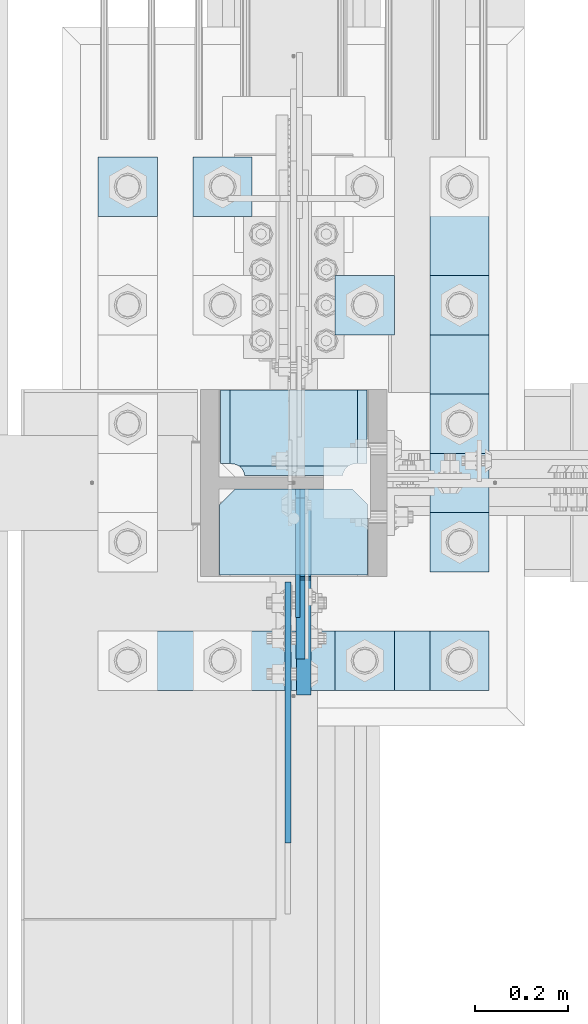
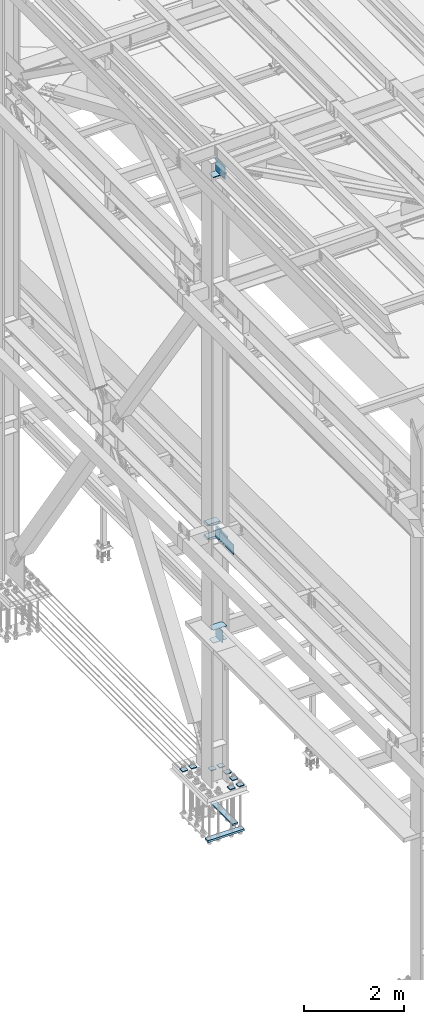
# One storey, part 3343 of 3843: 19 plates, 3 elements without a shape of their own.
"""IFC2X3 building model written with IfcOpenShell, lengths in millimetres."""

from ifc_helpers import new_model, si_unit, frame, origin_with_axes, place, context, subcontext, project, spatial, faceted_brep, material, type_object, element, aggregate, save


model = new_model("IFC2X3")

# Units and contexts
model_context = context("Model", 3, precision=1e-05, world=origin_with_axes())
body_context = subcontext(model_context, "Body", "Model", "MODEL_VIEW")
ifc_project = project(units=[si_unit("LENGTHUNIT", "METRE", prefix="MILLI"), si_unit("AREAUNIT", "SQUARE_METRE"), si_unit("VOLUMEUNIT", "CUBIC_METRE"), si_unit("MASSUNIT", "GRAM", prefix="KILO"), si_unit("TIMEUNIT", "SECOND"), si_unit("PLANEANGLEUNIT", "RADIAN"), si_unit("SOLIDANGLEUNIT", "STERADIAN"), si_unit("THERMODYNAMICTEMPERATUREUNIT", "DEGREE_CELSIUS"), si_unit("LUMINOUSINTENSITYUNIT", "LUMEN")], contexts=[model_context])

# Site, building, storey
site_placement = place(None, origin_with_axes())
site = spatial("IfcSite", under=ifc_project, at=site_placement, CompositionType="ELEMENT")
building_placement = place(site_placement, origin_with_axes())
building = spatial("IfcBuilding", under=site, at=building_placement, Name="Undefined", CompositionType="ELEMENT")
storey_placement = place(building_placement, origin_with_axes())
storey = spatial("IfcBuildingStorey", under=building, at=storey_placement, Name="Undefined", CompositionType="ELEMENT", Elevation=0.0)

# Assembly, plates
assembly_1_placement = place(storey_placement, origin_with_axes())
assembly_1 = element("IfcElementAssembly", 1, at=assembly_1_placement, inside=storey, Name="COLUMN", AssemblyPlace="NOTDEFINED", PredefinedType="RIGID_FRAME")
ifc_material = material(Name="STEEL/A572-50")
plate_type_1 = type_object("IfcPlateType", PredefinedType="NOTDEFINED")
plate_1_placement = place(assembly_1_placement, frame((36417.25, 67075.05, 33688.3375), z_axis=(1.0, 0.0, 0.0), x_axis=(0.0, 1.0, 0.0)))
plate_1 = element("IfcPlate", 2, at=plate_1_placement, type_object=plate_type_1, material=ifc_material, Name="PLATE", context=body_context, shape_type="Brep", body=[
    faceted_brep([(0.0, -4.76249999999709, 0.0), (0.0, -4.76249999785796, 317.500000005042), (0.0, 4.76250000210712, 317.50000000505), (0.0, 4.76249999999709, 0.0), (150.81249847413, -4.76249999999709, 317.5), (150.81249847413, 4.76249999999709, 317.5), (184.150000000009, -4.76249999999709, 284.162498474121), (184.150000000009, 4.76249999999709, 284.162498474121), (184.150000000009, -4.76249999999709, 33.3375015258789), (184.150000000009, 4.76249999999709, 33.3375015258789), (150.81249847413, -4.76249999999709, 0.0), (150.81249847413, 4.76249999999709, 0.0)], [[[0, 1, 2, 3]], [[1, 4, 5, 2]], [[4, 6, 7, 5]], [[6, 8, 9, 7]], [[8, 10, 11, 9]], [[10, 0, 3, 11]], [[5, 7, 9, 11, 3, 2]], [[10, 8, 6, 4, 1, 0]]]),
])
plate_2_placement = place(assembly_1_placement, frame((36417.25, 67075.05, 34002.6625), z_axis=(1.0, 0.0, 0.0), x_axis=(0.0, 1.0, 0.0)))
plate_2 = element("IfcPlate", 3, at=plate_2_placement, type_object=plate_type_1, material=ifc_material, Name="PLATE", context=body_context, shape_type="Brep", body=[
    faceted_brep([(0.0, -4.76249999999709, 0.0), (0.0, -4.76249999785796, 317.500000005042), (0.0, 4.76250000210712, 317.50000000505), (0.0, 4.76249999999709, 0.0), (150.81249847413, -4.76249999999709, 317.5), (150.81249847413, 4.76249999999709, 317.5), (184.150000000009, -4.76249999999709, 284.162498474121), (184.150000000009, 4.76249999999709, 284.162498474121), (184.150000000009, -4.76249999999709, 33.3375015258789), (184.150000000009, 4.76249999999709, 33.3375015258789), (150.81249847413, -4.76249999999709, 0.0), (150.81249847413, 4.76249999999709, 0.0)], [[[0, 1, 2, 3]], [[1, 4, 5, 2]], [[4, 6, 7, 5]], [[6, 8, 9, 7]], [[8, 10, 11, 9]], [[10, 0, 3, 11]], [[5, 7, 9, 11, 3, 2]], [[10, 8, 6, 4, 1, 0]]]),
])
plate_type_2 = type_object("IfcPlateType", PredefinedType="NOTDEFINED")
plate_3_placement = place(assembly_1_placement, frame((36736.3375, 67471.1313, 36085.4625), z_axis=(-1.0, 0.0, 0.0), x_axis=(0.0, -1.0, 0.0)))
plate_3 = element("IfcPlate", 4, at=plate_3_placement, type_object=plate_type_2, material=ifc_material, Name="PLATE", context=body_context, shape_type="Brep", body=[
    faceted_brep([(169.7353359673, 6.12970259824215, 50.1051604685563), (163.413638768514, 17.0792088240414, 43.7834632697632), (163.192342336726, 17.4625000000015, 43.3491445679101), (163.192342336726, 17.4625000000015, 277.325855432093), (163.413638768514, 17.0792088240414, 276.89153673024), (169.7353359673, 6.12970259824215, 270.569839531447), (177.701139149976, -7.66747323724849, 266.511060084209), (183.356300047686, -17.4625000000015, 265.61537059048), (183.356300047686, -17.4625000000015, 55.059629409523), (177.701139149976, -7.66747323724849, 54.1639399157939), (0.0, 17.4625000000015, 297.336542336721), (0.0, -17.4625000000015, 317.500500047689), (157.956299237063, -17.4625000000015, 317.500500047689), (157.956299237063, 17.4625000000015, 297.336542336721), (157.956299237063, 17.4625000000015, 23.3384576632816), (157.956299237063, -17.4625000000015, 3.17449995231436), (0.0, -17.4625000000015, 3.17449995232164), (0.0, 17.4625000000015, 23.3384576632816), (157.956299237063, -17.4625000000015, 293.687500762942), (157.956299237063, 17.4625000000015, 293.687500762942), (159.354859321276, -17.4625000000015, 284.857339912916), (159.354859321276, 17.4625000000015, 284.857339912916), (163.413638768514, -17.4625000000015, 276.89153673024), (169.7353359673, -17.4625000000015, 270.569839531447), (177.701139149984, -17.4625000000015, 266.511060084209), (177.701139149984, -17.4625000000015, 54.1639399157939), (169.7353359673, -17.4625000000015, 50.1051604685563), (163.413638768514, -17.4625000000015, 43.7834632697632), (159.354859321276, -17.4625000000015, 35.8176600870866), (159.354859321276, 17.4625000000015, 35.8176600870866), (157.956299237063, -17.4625000000015, 26.9874992370605), (157.956299237063, 17.4625000000015, 26.9874992370605)], [[[0, 1, 2, 3, 4, 5, 6, 7, 8, 9]], [[10, 11, 12, 13]], [[14, 15, 16, 17]], [[17, 16, 11, 10]], [[18, 19, 13, 12]], [[18, 20, 21, 19]], [[21, 20, 22, 4, 3]], [[22, 23, 5, 4]], [[23, 24, 6, 5]], [[24, 7, 6]], [[25, 9, 8]], [[25, 26, 0, 9]], [[26, 27, 1, 0]], [[27, 28, 29, 2, 1]], [[28, 30, 31, 29]], [[31, 30, 15, 14]], [[29, 31, 14, 17, 10, 13, 19, 21, 3, 2]], [[15, 30, 28, 27, 26, 25, 8, 7, 24, 23, 22, 20, 18, 12, 11, 16]]]),
])
plate_4_placement = place(assembly_1_placement, frame((36736.3375, 67471.1313, 36418.8375), z_axis=(-1.0, 0.0, 0.0), x_axis=(0.0, -1.0, 0.0)))
plate_4 = element("IfcPlate", 5, at=plate_4_placement, type_object=plate_type_2, material=ifc_material, Name="PLATE", context=body_context, shape_type="Brep", body=[
    faceted_brep([(169.7353359673, 6.12970259824215, 50.1051604685563), (163.413638768514, 17.0792088240414, 43.7834632697632), (163.192342336726, 17.4625000000015, 43.3491445679101), (163.192342336726, 17.4625000000015, 277.325855432093), (163.413638768514, 17.0792088240414, 276.89153673024), (169.7353359673, 6.12970259824215, 270.569839531447), (177.701139149976, -7.66747323724849, 266.511060084209), (183.356300047686, -17.4625000000015, 265.61537059048), (183.356300047686, -17.4625000000015, 55.059629409523), (177.701139149976, -7.66747323724849, 54.1639399157939), (0.0, 17.4625000000015, 297.336542336721), (0.0, -17.4625000000015, 317.500500047689), (157.956299237063, -17.4625000000015, 317.500500047689), (157.956299237063, 17.4625000000015, 297.336542336721), (157.956299237063, 17.4625000000015, 23.3384576632816), (157.956299237063, -17.4625000000015, 3.17449995231436), (0.0, -17.4625000000015, 3.17449995232164), (0.0, 17.4625000000015, 23.3384576632816), (157.956299237063, -17.4625000000015, 293.687500762942), (157.956299237063, 17.4625000000015, 293.687500762942), (159.354859321276, -17.4625000000015, 284.857339912916), (159.354859321276, 17.4625000000015, 284.857339912916), (163.413638768514, -17.4625000000015, 276.89153673024), (169.7353359673, -17.4625000000015, 270.569839531447), (177.701139149984, -17.4625000000015, 266.511060084209), (177.701139149984, -17.4625000000015, 54.1639399157939), (169.7353359673, -17.4625000000015, 50.1051604685563), (163.413638768514, -17.4625000000015, 43.7834632697632), (159.354859321276, -17.4625000000015, 35.8176600870866), (159.354859321276, 17.4625000000015, 35.8176600870866), (157.956299237063, -17.4625000000015, 26.9874992370605), (157.956299237063, 17.4625000000015, 26.9874992370605)], [[[0, 1, 2, 3, 4, 5, 6, 7, 8, 9]], [[10, 11, 12, 13]], [[14, 15, 16, 17]], [[17, 16, 11, 10]], [[18, 19, 13, 12]], [[18, 20, 21, 19]], [[21, 20, 22, 4, 3]], [[22, 23, 5, 4]], [[23, 24, 6, 5]], [[24, 7, 6]], [[25, 9, 8]], [[25, 26, 0, 9]], [[26, 27, 1, 0]], [[27, 28, 29, 2, 1]], [[28, 30, 31, 29]], [[31, 30, 15, 14]], [[29, 31, 14, 17, 10, 13, 19, 21, 3, 2]], [[15, 30, 28, 27, 26, 25, 8, 7, 24, 23, 22, 20, 18, 12, 11, 16]]]),
])
plate_type_3 = type_object("IfcPlateType", PredefinedType="NOTDEFINED")
plate_5_placement = place(assembly_1_placement, frame((36417.25, 67075.05, 45059.5999999882), z_axis=(1.0, 0.0, 0.0), x_axis=(0.0, 1.0, 0.0)))
plate_5 = element("IfcPlate", 6, at=plate_5_placement, type_object=plate_type_3, material=ifc_material, Name="PLATE", context=body_context, shape_type="Brep", body=[
    faceted_brep([(0.0, -9.52500000000146, 0.0), (0.0, -9.52500000000146, 317.5), (0.0, 9.52500000000146, 317.5), (0.0, 9.52500000000146, 0.0), (150.81249847413, -9.52500000000146, 317.5), (150.81249847413, 9.52500000000146, 317.5), (184.150000000009, -9.52500000000146, 284.162498474121), (184.150000000009, 9.52500000000146, 284.162498474121), (184.150000000009, -9.52500000000146, 33.3375015258789), (184.150000000009, 9.52500000000146, 33.3375015258789), (150.81249847413, -9.52500000000146, 0.0), (150.81249847413, 9.52500000000146, 0.0)], [[[0, 1, 2, 3]], [[1, 4, 5, 2]], [[4, 6, 7, 5]], [[6, 8, 9, 7]], [[8, 10, 11, 9]], [[10, 0, 3, 11]], [[5, 7, 9, 11, 3, 2]], [[10, 8, 6, 4, 1, 0]]]),
])
plate_type_4 = type_object("IfcPlateType", PredefinedType="NOTDEFINED")
plate_6_placement = place(assembly_1_placement, frame((36590.2875004278, 67259.2, 45088.1750027919), z_axis=(0.0, -0.707106781186682, 0.707106781186413), x_axis=(0.0, -0.707106781186548, -0.707106781186548)))
plate_6 = element("IfcPlate", 7, at=plate_6_placement, type_object=plate_type_4, material=ifc_material, Name="PLATE", context=body_context, shape_type="Brep", body=[
    faceted_brep([(0.0, -9.52500000000146, 0.0), (-206.545892322774, -9.52500000000146, 206.545889244429), (-206.545892322774, 9.52500000000146, 206.545889244429), (0.0, 9.52500000000146, 0.0), (-206.545892322807, -9.52500000000146, 233.486657406793), (-206.545892322807, 9.52500000000146, 233.486657406793), (-87.5574981562204, -9.52500000000146, 352.475049513436), (-87.5574981562204, 9.52500000000146, 352.475049513436), (-83.4373216675631, -9.52500000000146, 349.722035643659), (-83.4373216675631, 9.52500000000146, 349.722035643659), (-78.5772421423244, -9.52500000000146, 348.755305757295), (-78.5772421423244, 9.52500000000146, 348.755305757295), (-73.7171626314957, -9.52500000000146, 349.722035716099), (-73.7171626314957, 9.52500000000146, 349.722035716099), (-69.5969861838676, -9.52500000000146, 352.47504964727), (-69.5969861838676, 9.52500000000146, 352.47504964727), (47.1463462352222, -9.52500000000146, 469.218383806307), (47.1463462352222, 9.52500000000146, 469.218383806307), (271.652750933881, -9.52500000000146, 244.711982453664), (271.652750933881, 9.52500000000146, 244.711982453664), (26.9407683632344, -9.52499999999964, 2.03726813197136e-10), (26.9407683632344, 9.52499999999964, 2.03726813197136e-10)], [[[0, 1, 2, 3]], [[1, 4, 5, 2]], [[4, 6, 7, 5]], [[6, 8, 9, 7]], [[8, 10, 11, 9]], [[10, 12, 13, 11]], [[12, 14, 15, 13]], [[14, 16, 17, 15]], [[16, 18, 19, 17]], [[18, 20, 21, 19]], [[20, 0, 3, 21]], [[5, 7, 9, 11, 13, 15, 17, 19, 21, 3, 2]], [[20, 18, 16, 14, 12, 10, 8, 6, 4, 1, 0]]]),
])

# Assembly, plate
assembly_2_placement = place(storey_placement, origin_with_axes())
assembly_2 = element("IfcElementAssembly", 8, at=assembly_2_placement, inside=storey, Name="BEAM", AssemblyPlace="NOTDEFINED", PredefinedType="RIGID_FRAME")
plate_type_5 = type_object("IfcPlateType", PredefinedType="NOTDEFINED")
plate_7_placement = place(assembly_2_placement, frame((36564.09375, 67059.175, 36385.5), z_axis=(0.0, -1.0, 0.0), x_axis=(0.0, 0.0, -1.0)))
plate_7 = element("IfcPlate", 9, at=plate_7_placement, type_object=plate_type_5, material=ifc_material, Name="PLATE", context=body_context, shape_type="Brep", body=[
    faceted_brep([(0.0, -6.3499999046162, 0.0), (-1.27693056128919e-09, -6.34999999999854, 558.800000006726), (0.0, 6.35000000000036, 558.799999999988), (7.27595761418343e-12, 6.3499999046162, 0.0), (241.300003051758, -6.34999999999854, 558.800012207037), (241.300003051758, 6.34999999999854, 558.800012207037), (241.300003051758, -6.34999999999854, 0.0), (241.300003051758, 6.34999999999854, 0.0)], [[[0, 1, 2, 3]], [[1, 4, 5, 2]], [[4, 6, 7, 5]], [[6, 0, 3, 7]], [[5, 7, 3, 2]], [[6, 4, 1, 0]]]),
])
aggregate(assembly_2, [plate_7])

# Plate
plate_type_6 = type_object("IfcPlateType", PredefinedType="NOTDEFINED")
plate_8_placement = place(assembly_1_placement, frame((36597.43125, 67259.2, 36401.375), z_axis=(0.0, -1.0, 0.0), x_axis=(0.0, 0.0, -1.0)))
plate_8 = element("IfcPlate", 10, at=plate_8_placement, type_object=plate_type_6, material=ifc_material, Name="PLATE", context=body_context, shape_type="Brep", body=[
    faceted_brep([(6.54836185276508e-11, 15.875, 28.5750007629249), (298.449999999997, 15.875, 28.5749999999971), (298.449999999997, 6.34999923706346, 19.0499992370605), (279.400000762937, -12.6999999999971, 0.0), (19.0500015258731, -12.6999999999971, -6.33008312433958e-10), (0.0, 6.34999999999854, 19.0499992370605), (0.0, -15.875, 19.0499992370605), (0.0, -15.875, 187.325000000004), (0.0, 15.875, 187.325000000004), (3.17500019070576, -15.875, 187.325000000004), (3.17500019070576, 15.875, 187.325000000004), (8.03507970875216, -15.875, 188.291729922596), (8.03507970875216, 15.875, 188.291729922596), (12.1552561769058, -15.875, 191.044743823069), (12.1552561769058, 15.875, 191.044743823069), (14.908270077387, -15.875, 195.164920291223), (14.908270077387, 15.875, 195.164920291223), (15.8749999999709, -15.875, 200.02499980927), (15.8749999999709, 15.875, 200.02499980927), (15.875, -15.875, 441.325012207031), (15.875, 15.875, 441.325012207031), (257.175003051758, -15.875, 441.325012207031), (257.175003051758, 15.875, 441.325012207031), (257.175003051729, -15.875, 200.02499980927), (257.175003051729, 15.875, 200.02499980927), (258.14173297432, -15.875, 195.164920291223), (258.14173297432, 15.875, 195.164920291223), (260.894746874794, -15.875, 191.044743823069), (260.894746874794, 15.875, 191.044743823069), (265.014923342947, -15.875, 188.291729922596), (265.014923342947, 15.875, 188.291729922596), (269.875002860994, -15.875, 187.325000000004), (269.875002860994, 15.875, 187.325000000004), (298.449999999997, -15.875, 187.325000000004), (298.449999999997, 15.875, 187.325000000004), (298.449999999997, -15.875, 19.0499992370605), (279.400000762937, -15.875, 0.0), (19.0500015258804, -15.875, 0.0)], [[[0, 1, 2, 3, 4, 5]], [[6, 7, 8, 0, 5]], [[7, 9, 10, 8]], [[9, 11, 12, 10]], [[11, 13, 14, 12]], [[13, 15, 16, 14]], [[15, 17, 18, 16]], [[17, 19, 20, 18]], [[19, 21, 22, 20]], [[21, 23, 24, 22]], [[23, 25, 26, 24]], [[25, 27, 28, 26]], [[27, 29, 30, 28]], [[29, 31, 32, 30]], [[31, 33, 34, 32]], [[34, 33, 35, 2, 1]], [[35, 36, 3, 2]], [[36, 37, 4, 3]], [[37, 6, 5, 4]], [[8, 10, 12, 14, 16, 18, 20, 22, 24, 26, 28, 30, 32, 34, 1, 0]], [[37, 36, 35, 33, 31, 29, 27, 25, 23, 21, 19, 17, 15, 13, 11, 9, 7, 6]]]),
])

plate_type_7 = type_object("IfcPlateType", PredefinedType="NOTDEFINED")
plate_9_placement = place(assembly_1_placement, frame((36584.73125, 67259.2, 33712.1500027914), z_axis=(0.0, -0.707106781186682, 0.707106781186413), x_axis=(0.0, -0.707106781186548, -0.707106781186548)))
plate_9 = element("IfcPlate", 11, at=plate_9_placement, type_object=plate_type_7, material=ifc_material, Name="PLATE", context=body_context, shape_type="Brep", body=[
    faceted_brep([(0.0, -4.76249999999709, 0.0), (-188.585379946875, -4.76249999999709, 188.585377136231), (-188.585379946875, 4.76249999999709, 188.585377136231), (0.0, 4.76249999999709, 0.0), (-188.585379946759, -4.76249999999709, 215.526145298725), (-188.585379946759, 4.76249999999709, 215.526145298725), (-6.73518993152538, -4.76249999999709, 397.376334478104), (-6.73518993152538, 4.76249999999709, 397.376334478104), (208.790958579193, -4.76249999999709, 181.850189179575), (208.790958579193, 4.76249999999709, 181.850189179575), (26.9407683631998, -4.76249999999709, 1.30967237055302e-10), (26.9407683631998, 4.76249999999709, 1.30967237055302e-10)], [[[0, 1, 2, 3]], [[1, 4, 5, 2]], [[4, 6, 7, 5]], [[6, 8, 9, 7]], [[8, 10, 11, 9]], [[10, 0, 3, 11]], [[5, 7, 9, 11, 3, 2]], [[10, 8, 6, 4, 1, 0]]]),
])

aggregate(assembly_1, [plate_5, plate_6, plate_8, plate_3, plate_4, plate_1, plate_2, plate_9])

# Assembly, plates
assembly_3_placement = place(storey_placement, origin_with_axes())
assembly_3 = element("IfcElementAssembly", 12, at=assembly_3_placement, inside=storey, Name="TEMPLATE", AssemblyPlace="NOTDEFINED", PredefinedType="RIGID_FRAME")
plate_type_8 = type_object("IfcPlateType", PredefinedType="NOTDEFINED")
plate_10_placement = place(assembly_3_placement, frame((36868.1, 66954.4, 30172.025), z_axis=(0.0, -1.0, 0.0), x_axis=(1.0, 0.0, 0.0)))
plate_10 = element("IfcPlate", 13, at=plate_10_placement, type_object=plate_type_8, material=ifc_material, Name="Washer Plate", context=body_context, shape_type="Brep", body=[
    faceted_brep([(0.0, -9.52500000000146, 0.0), (0.0, -9.52499999999418, 127.0), (0.0, 9.52499999999418, 127.0), (0.0, 9.52500000000146, 0.0), (127.0, -9.52500000000146, 127.0), (127.0, 9.52500000000146, 127.0), (127.0, -9.52500000000146, 0.0), (127.0, 9.52500000000146, 0.0)], [[[0, 1, 2, 3]], [[1, 4, 5, 2]], [[4, 6, 7, 5]], [[6, 0, 3, 7]], [[5, 7, 3, 2]], [[6, 4, 1, 0]]]),
])
plate_11_placement = place(assembly_3_placement, frame((36868.1, 67208.4, 30172.025), z_axis=(0.0, -1.0, 0.0), x_axis=(1.0, 0.0, 0.0)))
plate_11 = element("IfcPlate", 14, at=plate_11_placement, type_object=plate_type_8, material=ifc_material, Name="Washer Plate", context=body_context, shape_type="Brep", body=[
    faceted_brep([(0.0, -9.52500000000146, 0.0), (0.0, -9.52499999999418, 127.0), (0.0, 9.52499999999418, 127.0), (0.0, 9.52500000000146, 0.0), (127.0, -9.52500000000146, 127.0), (127.0, 9.52500000000146, 127.0), (127.0, -9.52500000000146, 0.0), (127.0, 9.52500000000146, 0.0)], [[[0, 1, 2, 3]], [[1, 4, 5, 2]], [[4, 6, 7, 5]], [[6, 0, 3, 7]], [[5, 7, 3, 2]], [[6, 4, 1, 0]]]),
])
plate_12_placement = place(assembly_3_placement, frame((36868.1, 67462.4, 30172.025), z_axis=(0.0, -1.0, 0.0), x_axis=(1.0, 0.0, 0.0)))
plate_12 = element("IfcPlate", 15, at=plate_12_placement, type_object=plate_type_8, material=ifc_material, Name="Washer Plate", context=body_context, shape_type="Brep", body=[
    faceted_brep([(0.0, -9.52500000000146, 0.0), (0.0, -9.52499999999418, 127.0), (0.0, 9.52499999999418, 127.0), (0.0, 9.52500000000146, 0.0), (127.0, -9.52500000000146, 127.0), (127.0, 9.52500000000146, 127.0), (127.0, -9.52500000000146, 0.0), (127.0, 9.52500000000146, 0.0)], [[[0, 1, 2, 3]], [[1, 4, 5, 2]], [[4, 6, 7, 5]], [[6, 0, 3, 7]], [[5, 7, 3, 2]], [[6, 4, 1, 0]]]),
])
plate_13_placement = place(assembly_3_placement, frame((36868.1, 67716.4, 30172.025), z_axis=(0.0, -1.0, 0.0), x_axis=(1.0, 0.0, 0.0)))
plate_13 = element("IfcPlate", 16, at=plate_13_placement, type_object=plate_type_8, material=ifc_material, Name="Washer Plate", context=body_context, shape_type="Brep", body=[
    faceted_brep([(0.0, -9.52500000000146, 0.0), (0.0, -9.52499999999418, 127.0), (0.0, 9.52499999999418, 127.0), (0.0, 9.52500000000146, 0.0), (127.0, -9.52500000000146, 127.0), (127.0, 9.52500000000146, 127.0), (127.0, -9.52500000000146, 0.0), (127.0, 9.52500000000146, 0.0)], [[[0, 1, 2, 3]], [[1, 4, 5, 2]], [[4, 6, 7, 5]], [[6, 0, 3, 7]], [[5, 7, 3, 2]], [[6, 4, 1, 0]]]),
])
plate_14_placement = place(assembly_3_placement, frame((36664.9, 66954.4, 30172.025), z_axis=(0.0, -1.0, 0.0), x_axis=(1.0, 0.0, 0.0)))
plate_14 = element("IfcPlate", 17, at=plate_14_placement, type_object=plate_type_8, material=ifc_material, Name="Washer Plate", context=body_context, shape_type="Brep", body=[
    faceted_brep([(0.0, -9.52500000000146, 0.0), (0.0, -9.52499999999418, 127.0), (0.0, 9.52499999999418, 127.0), (0.0, 9.52500000000146, 0.0), (127.0, -9.52500000000146, 127.0), (127.0, 9.52500000000146, 127.0), (127.0, -9.52500000000146, 0.0), (127.0, 9.52500000000146, 0.0)], [[[0, 1, 2, 3]], [[1, 4, 5, 2]], [[4, 6, 7, 5]], [[6, 0, 3, 7]], [[5, 7, 3, 2]], [[6, 4, 1, 0]]]),
])
plate_15_placement = place(assembly_3_placement, frame((36664.9, 67716.4, 30172.025), z_axis=(0.0, -1.0, 0.0), x_axis=(1.0, 0.0, 0.0)))
plate_15 = element("IfcPlate", 18, at=plate_15_placement, type_object=plate_type_8, material=ifc_material, Name="Washer Plate", context=body_context, shape_type="Brep", body=[
    faceted_brep([(0.0, -9.52500000000146, 0.0), (0.0, -9.52499999999418, 127.0), (0.0, 9.52499999999418, 127.0), (0.0, 9.52500000000146, 0.0), (127.0, -9.52500000000146, 127.0), (127.0, 9.52500000000146, 127.0), (127.0, -9.52500000000146, 0.0), (127.0, 9.52500000000146, 0.0)], [[[0, 1, 2, 3]], [[1, 4, 5, 2]], [[4, 6, 7, 5]], [[6, 0, 3, 7]], [[5, 7, 3, 2]], [[6, 4, 1, 0]]]),
])
plate_16_placement = place(assembly_3_placement, frame((36360.1, 67970.4, 30172.025), z_axis=(0.0, -1.0, 0.0), x_axis=(1.0, 0.0, 0.0)))
plate_16 = element("IfcPlate", 19, at=plate_16_placement, type_object=plate_type_8, material=ifc_material, Name="Washer Plate", context=body_context, shape_type="Brep", body=[
    faceted_brep([(0.0, -9.52500000000146, 0.0), (0.0, -9.52499999999418, 127.0), (0.0, 9.52499999999418, 127.0), (0.0, 9.52500000000146, 0.0), (127.0, -9.52500000000146, 127.0), (127.0, 9.52500000000146, 127.0), (127.0, -9.52500000000146, 0.0), (127.0, 9.52500000000146, 0.0)], [[[0, 1, 2, 3]], [[1, 4, 5, 2]], [[4, 6, 7, 5]], [[6, 0, 3, 7]], [[5, 7, 3, 2]], [[6, 4, 1, 0]]]),
])
plate_17_placement = place(assembly_3_placement, frame((36156.9, 67970.4, 30172.025), z_axis=(0.0, -1.0, 0.0), x_axis=(1.0, 0.0, 0.0)))
plate_17 = element("IfcPlate", 20, at=plate_17_placement, type_object=plate_type_8, material=ifc_material, Name="Washer Plate", context=body_context, shape_type="Brep", body=[
    faceted_brep([(0.0, -9.52500000000146, 0.0), (0.0, -9.52499999999418, 127.0), (0.0, 9.52499999999418, 127.0), (0.0, 9.52500000000146, 0.0), (127.0, -9.52500000000146, 127.0), (127.0, 9.52500000000146, 127.0), (127.0, -9.52500000000146, 0.0), (127.0, 9.52500000000146, 0.0)], [[[0, 1, 2, 3]], [[1, 4, 5, 2]], [[4, 6, 7, 5]], [[6, 0, 3, 7]], [[5, 7, 3, 2]], [[6, 4, 1, 0]]]),
])
plate_type_9 = type_object("IfcPlateType", PredefinedType="NOTDEFINED")
plate_18_placement = place(assembly_3_placement, frame((36868.1, 67081.4, 29089.35), z_axis=(0.0, 1.0, 0.0), x_axis=(1.0, 0.0, 0.0)))
plate_18 = element("IfcPlate", 21, at=plate_18_placement, type_object=plate_type_9, material=ifc_material, Name="PLATE", context=body_context, shape_type="Brep", body=[
    faceted_brep([(0.0, -19.0500000000029, 0.0), (-7.27595761418343e-12, -19.0499999999993, 889.0), (-7.27595761418343e-12, 19.0499999999993, 889.0), (0.0, 19.0500000000029, 0.0), (127.0, -19.0499999999993, 889.0), (127.0, 19.0499999999993, 889.0), (127.0, -19.0499999999993, 0.0), (127.0, 19.0499999999993, 0.0)], [[[0, 1, 2, 3]], [[1, 4, 5, 2]], [[4, 6, 7, 5]], [[6, 0, 3, 7]], [[5, 7, 3, 2]], [[6, 4, 1, 0]]]),
])
plate_type_10 = type_object("IfcPlateType", PredefinedType="NOTDEFINED")
plate_19_placement = place(assembly_3_placement, frame((36995.1, 66827.4, 29083.0), z_axis=(-1.0, 0.0, 0.0), x_axis=(0.0, 1.0, 0.0)))
plate_19 = element("IfcPlate", 22, at=plate_19_placement, type_object=plate_type_10, material=ifc_material, Name="PLATE", context=body_context, shape_type="Brep", body=[
    faceted_brep([(0.0, -25.3999996185303, 0.0), (0.0, -25.4000000000015, 838.200012207031), (0.0, 25.4000000000015, 838.200012207031), (0.0, 25.3999996185303, 0.0), (127.0, -25.4000000000015, 838.200012207031), (127.0, 25.4000000000015, 838.200012207031), (127.0, -25.4000000000015, 0.0), (127.0, 25.4000000000015, 0.0)], [[[0, 1, 2, 3]], [[1, 4, 5, 2]], [[4, 6, 7, 5]], [[6, 0, 3, 7]], [[5, 7, 3, 2]], [[6, 4, 1, 0]]]),
])
aggregate(assembly_3, [plate_10, plate_11, plate_12, plate_13, plate_14, plate_15, plate_16, plate_17, plate_19, plate_18])

save(model, "model.ifc")
